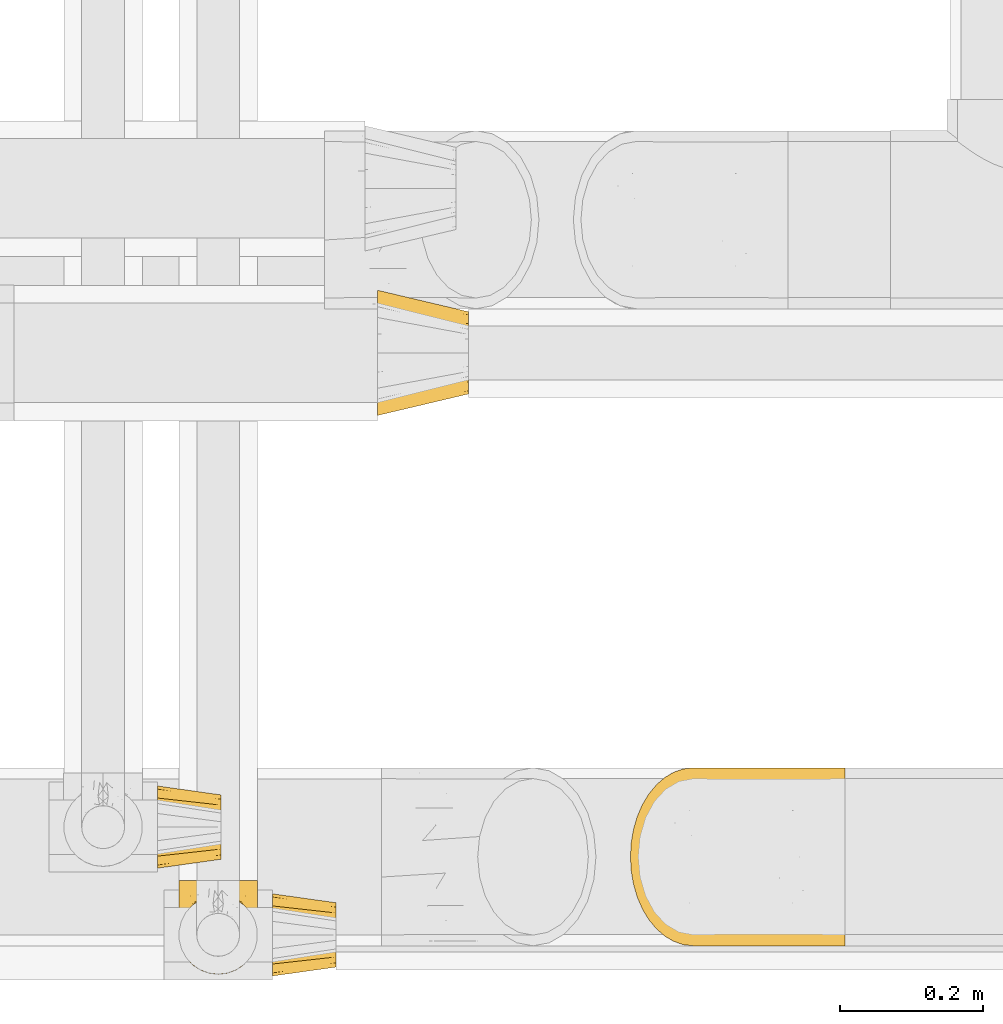
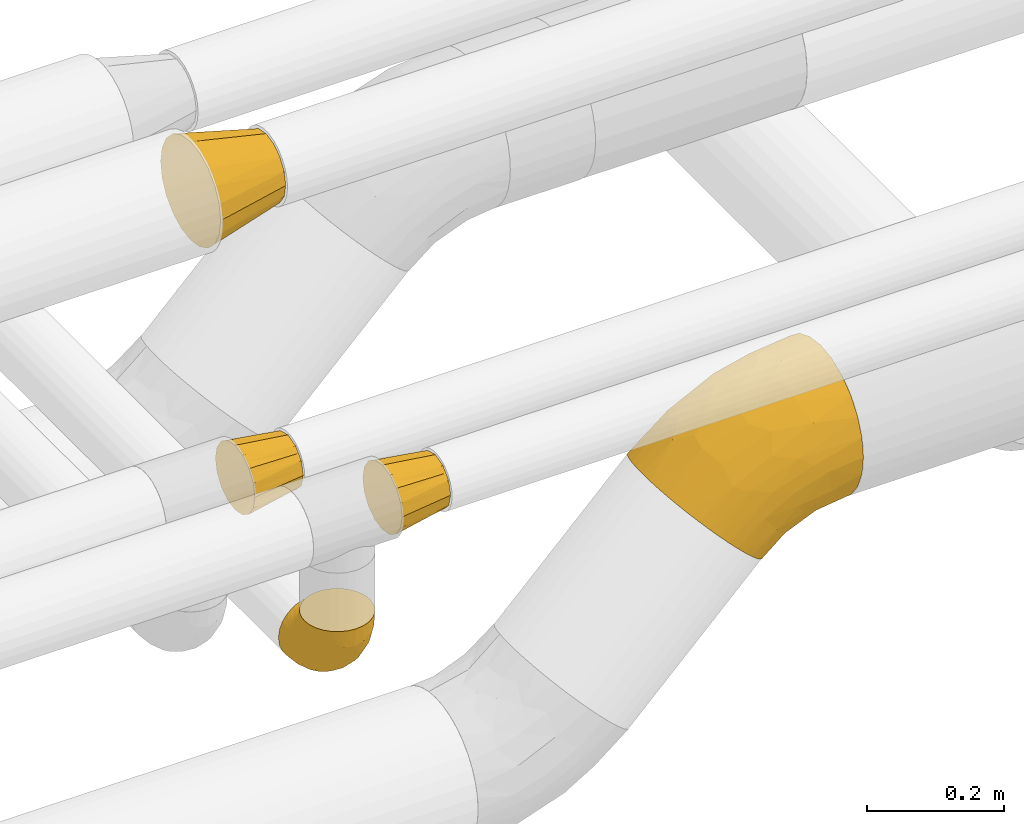
# One storey, part 184 of 827: 5 coverings.
"""IFC2X3 building model written with IfcOpenShell, lengths in millimetres."""

from ifc_helpers import new_model, entity, si_unit, converted_unit, derived_unit, direction, frame, origin, place, context, subcontext, project, spatial, faceted_brep, element, save


model = new_model("IFC2X3")

# Units and contexts
model_context = context("Model", 3, precision=0.01, world=origin(), true_north=direction((6.12303176911189e-17, 1.0)))
body_context = subcontext(model_context, "Body", "Model", "MODEL_VIEW")
ifc_project = project(units=[si_unit("LENGTHUNIT", "METRE", prefix="MILLI"), si_unit("AREAUNIT", "SQUARE_METRE"), si_unit("VOLUMEUNIT", "CUBIC_METRE"), converted_unit("PLANEANGLEUNIT", "DEGREE", entity("IfcRatioMeasure", 0.0174532925199433), si_unit("PLANEANGLEUNIT", "RADIAN"), dimensions=[0, 0, 0, 0, 0, 0, 0]), si_unit("MASSUNIT", "GRAM", prefix="KILO"), derived_unit("MASSDENSITYUNIT", [(si_unit("MASSUNIT", "GRAM", prefix="KILO"), 1), (si_unit("LENGTHUNIT", "METRE"), -3)]), derived_unit("MOMENTOFINERTIAUNIT", [(si_unit("LENGTHUNIT", "METRE"), 4)]), si_unit("TIMEUNIT", "SECOND"), si_unit("FREQUENCYUNIT", "HERTZ"), si_unit("THERMODYNAMICTEMPERATUREUNIT", "DEGREE_CELSIUS"), derived_unit("THERMALTRANSMITTANCEUNIT", [(si_unit("MASSUNIT", "GRAM", prefix="KILO"), 1), (si_unit("THERMODYNAMICTEMPERATUREUNIT", "KELVIN"), -1), (si_unit("TIMEUNIT", "SECOND"), -3)]), derived_unit("VOLUMETRICFLOWRATEUNIT", [(si_unit("LENGTHUNIT", "METRE"), 3), (si_unit("TIMEUNIT", "SECOND"), -1)]), derived_unit("MASSFLOWRATEUNIT", [(si_unit("MASSUNIT", "GRAM", prefix="KILO"), 1), (si_unit("TIMEUNIT", "SECOND"), -1)]), derived_unit("ROTATIONALFREQUENCYUNIT", [(si_unit("TIMEUNIT", "SECOND"), -1)]), si_unit("ELECTRICCURRENTUNIT", "AMPERE"), si_unit("ELECTRICVOLTAGEUNIT", "VOLT"), si_unit("POWERUNIT", "WATT"), si_unit("FORCEUNIT", "NEWTON", prefix="KILO"), si_unit("ILLUMINANCEUNIT", "LUX"), si_unit("LUMINOUSFLUXUNIT", "LUMEN"), si_unit("LUMINOUSINTENSITYUNIT", "CANDELA"), derived_unit("USERDEFINED", [(si_unit("MASSUNIT", "GRAM", prefix="KILO"), -1), (si_unit("LENGTHUNIT", "METRE"), -2), (si_unit("TIMEUNIT", "SECOND"), 3), (si_unit("LUMINOUSFLUXUNIT", "LUMEN"), 1)]), derived_unit("LINEARVELOCITYUNIT", [(si_unit("LENGTHUNIT", "METRE"), 1), (si_unit("TIMEUNIT", "SECOND"), -1)]), si_unit("PRESSUREUNIT", "PASCAL"), derived_unit("USERDEFINED", [(si_unit("LENGTHUNIT", "METRE"), -2), (si_unit("MASSUNIT", "GRAM", prefix="KILO"), 1), (si_unit("TIMEUNIT", "SECOND"), -2)]), derived_unit("LINEARFORCEUNIT", [(si_unit("MASSUNIT", "GRAM", prefix="KILO"), 1), (si_unit("LENGTHUNIT", "METRE"), 1), (si_unit("TIMEUNIT", "SECOND"), -2), (si_unit("LENGTHUNIT", "METRE"), -1)]), derived_unit("PLANARFORCEUNIT", [(si_unit("MASSUNIT", "GRAM", prefix="KILO"), 1), (si_unit("LENGTHUNIT", "METRE"), 1), (si_unit("TIMEUNIT", "SECOND"), -2), (si_unit("LENGTHUNIT", "METRE"), -2)])], contexts=[model_context])

# Site, building, storey
site_placement = place(None, origin())
site = spatial("IfcSite", under=ifc_project, at=site_placement, CompositionType="ELEMENT")
building_placement = place(site_placement, origin())
building = spatial("IfcBuilding", under=site, at=building_placement, CompositionType="ELEMENT")
storey_placement = place(building_placement, frame((0.0, 0.0, 28200.0)))
storey = spatial("IfcBuildingStorey", under=building, at=storey_placement, Name="08", CompositionType="ELEMENT", Elevation=28200.0)

# Coverings
covering_1_placement = place(storey_placement, frame((36852.83, 6990.9, 3010.9)))
element("IfcCovering", 1, at=covering_1_placement, inside=storey, Name=":ADSK_", ObjectType=":ADSK_", PredefinedType="INSULATION", context=body_context, shape_type="Brep", body=[
    faceted_brep([(0.0, 62.06, 172.31), (0.0, 89.1, 176.6), (0.0, 116.13, 172.31), (0.0, 140.53, 159.88), (0.0, 159.88, 140.53), (0.0, 172.31, 116.13), (0.0, 176.6, 89.1), (0.0, 172.31, 62.06), (0.0, 159.88, 37.66), (0.0, 140.53, 18.31), (0.0, 116.13, 5.88), (0.0, 89.1, 1.6), (0.0, 62.06, 5.88), (0.0, 37.66, 18.31), (0.0, 18.31, 37.66), (0.0, 5.88, 62.06), (0.0, 1.6, 89.1), (0.0, 5.88, 116.13), (0.0, 18.31, 140.53), (0.0, 37.66, 159.88), (127.0, 31.6, 89.1), (127.0, 33.78, 78.09), (127.0, 35.97, 67.09), (127.0, 42.2, 57.76), (127.0, 48.44, 48.44), (127.0, 57.76, 42.2), (127.0, 67.09, 35.97), (127.0, 78.09, 33.78), (127.0, 89.1, 31.6), (127.0, 100.1, 33.78), (127.0, 111.1, 35.97), (127.0, 120.43, 42.2), (127.0, 129.75, 48.44), (127.0, 135.99, 57.76), (127.0, 142.22, 67.09), (127.0, 144.41, 78.09), (127.0, 146.6, 89.1), (127.0, 144.41, 100.1), (127.0, 142.22, 111.1), (127.0, 135.99, 120.43), (127.0, 129.75, 129.75), (127.0, 120.43, 135.99), (127.0, 111.1, 142.22), (127.0, 100.1, 144.41), (127.0, 89.1, 146.6), (127.0, 78.09, 144.41), (127.0, 67.09, 142.22), (127.0, 57.76, 135.99), (127.0, 48.44, 129.75), (127.0, 42.2, 120.43), (127.0, 35.97, 111.1), (127.0, 33.78, 100.1)], [[[0, 1, 2, 3, 4, 5, 6, 7, 8, 9, 10, 11, 12, 13, 14, 15, 16, 17, 18, 19]], [[20, 21, 22, 23, 24, 25, 26, 27, 28, 29, 30, 31, 32, 33, 34, 35, 36, 37, 38, 39, 40, 41, 42, 43, 44, 45, 46, 47, 48, 49, 50, 51]], [[6, 35, 7]], [[35, 6, 36]], [[34, 8, 7]], [[10, 30, 29]], [[35, 34, 7]], [[8, 34, 33, 32]], [[9, 32, 31, 30]], [[11, 29, 28]], [[10, 9, 30]], [[11, 10, 29]], [[32, 9, 8]], [[11, 27, 12]], [[27, 11, 28]], [[26, 13, 12]], [[15, 22, 21]], [[27, 26, 12]], [[13, 26, 25, 24]], [[14, 24, 23, 22]], [[16, 21, 20]], [[15, 14, 22]], [[16, 15, 21]], [[24, 14, 13]], [[16, 51, 17]], [[51, 16, 20]], [[50, 18, 17]], [[0, 46, 45]], [[51, 50, 17]], [[18, 50, 49, 48]], [[19, 48, 47, 46]], [[1, 45, 44]], [[0, 19, 46]], [[1, 0, 45]], [[48, 19, 18]], [[1, 43, 2]], [[43, 1, 44]], [[42, 3, 2]], [[5, 38, 37]], [[43, 42, 2]], [[3, 42, 41, 40]], [[4, 40, 39, 38]], [[6, 37, 36]], [[5, 4, 38]], [[6, 5, 37]], [[40, 4, 3]]]),
])
covering_2_placement = place(storey_placement, frame((36572.9, 6209.07, 2793.25)))
element("IfcCovering", 2, at=covering_2_placement, inside=storey, Name=":ADSK_", ObjectType=":ADSK_", PredefinedType="INSULATION", context=body_context, shape_type="Brep", body=[
    faceted_brep([(13.63, 22.35, 132.75), (22.37, 13.62, 132.75), (32.83, 7.05, 132.75), (44.49, 2.97, 132.75), (56.75, 1.6, 132.75), (69.02, 2.98, 132.75), (80.68, 7.06, 132.75), (91.14, 13.63, 132.75), (99.87, 22.37, 132.75), (106.44, 32.83, 132.75), (110.52, 44.49, 132.75), (111.9, 56.75, 132.75), (110.94, 65.19, 132.75), (110.51, 69.02, 132.75), (108.47, 74.85, 132.75), (106.43, 80.68, 132.75), (99.86, 91.14, 132.75), (91.12, 99.87, 132.75), (80.66, 106.44, 132.75), (69.0, 110.52, 132.75), (56.75, 111.9, 132.75), (44.47, 110.51, 132.75), (32.81, 106.43, 132.75), (22.35, 99.86, 132.75), (13.62, 91.12, 132.75), (7.05, 80.66, 132.75), (5.01, 74.83, 132.75), (2.97, 69.0, 132.75), (2.55, 65.19, 132.75), (1.6, 56.75, 132.75), (2.98, 44.47, 132.75), (7.06, 32.81, 132.75), (95.74, 132.75, 95.74), (100.12, 132.75, 90.03), (104.51, 132.75, 84.32), (110.02, 132.75, 71.02), (110.78, 132.75, 65.22), (111.34, 132.75, 60.98), (111.9, 132.75, 56.75), (110.02, 132.75, 42.47), (104.51, 132.75, 29.17), (95.74, 132.75, 17.75), (84.32, 132.75, 8.98), (71.02, 132.75, 3.47), (56.75, 132.75, 1.6), (42.47, 132.75, 3.47), (29.17, 132.75, 8.98), (17.75, 132.75, 17.75), (8.98, 132.75, 29.17), (3.47, 132.75, 42.47), (1.6, 132.75, 56.75), (2.71, 132.75, 65.22), (3.47, 132.75, 71.02), (8.98, 132.75, 84.32), (13.37, 132.75, 90.03), (17.75, 132.75, 95.74), (29.17, 132.75, 104.51), (42.47, 132.75, 110.02), (56.75, 132.75, 111.9), (71.02, 132.75, 110.02), (84.32, 132.75, 104.51), (7.44, 106.09, 35.64), (2.99, 106.29, 48.47), (56.75, 98.8, 6.06), (46.96, 110.62, 4.36), (37.21, 79.56, 16.79), (27.14, 82.88, 20.82), (37.53, 101.82, 8.85), (24.94, 109.51, 13.94), (3.17, 60.24, 80.96), (1.6, 62.53, 103.66), (1.6, 66.65, 97.5), (1.6, 70.77, 91.33), (1.6, 74.89, 85.17), (1.6, 79.01, 79.01), (5.69, 75.42, 54.67), (12.02, 78.6, 38.99), (39.71, 54.94, 30.54), (56.75, 67.17, 19.17), (56.75, 40.01, 40.01), (15.45, 101.35, 24.66), (11.78, 27.42, 109.14), (56.75, 6.06, 98.8), (40.29, 7.89, 101.8), (9.49, 54.81, 63.23), (2.53, 49.8, 109.61), (2.41, 83.59, 62.85), (1.6, 85.17, 74.89), (1.6, 91.33, 70.77), (1.6, 97.5, 66.65), (1.6, 103.66, 62.53), (20.26, 19.66, 101.4), (15.42, 32.92, 80.83), (47.01, 86.86, 10.81), (31.45, 19.74, 79.3), (42.38, 29.98, 54.37), (44.67, 15.6, 76.81), (29.07, 11.19, 109.78), (29.36, 42.02, 48.41), (1.6, 58.54, 123.73), (1.6, 60.33, 114.72), (22.77, 25.28, 80.6), (24.08, 62.01, 35.27), (7.53, 42.85, 86.96), (6.23, 37.14, 110.67), (56.75, 19.17, 67.17), (17.33, 51.44, 52.02), (1.6, 114.72, 60.33), (1.6, 119.22, 59.44), (1.6, 123.73, 58.54), (6.73, 115.76, 82.8), (2.92, 110.4, 72.79), (3.19, 102.67, 77.6), (3.2, 119.74, 71.3), (19.32, 125.52, 98.0), (12.48, 123.09, 90.73), (14.6, 115.24, 96.3), (7.81, 124.18, 82.91), (7.5, 108.76, 87.53), (9.9, 105.53, 94.55), (45.9, 112.2, 125.07), (31.09, 109.92, 117.99), (35.08, 108.4, 125.94), (9.55, 89.3, 113.64), (3.53, 78.37, 103.99), (4.99, 78.09, 116.68), (17.56, 110.58, 102.88), (22.47, 108.54, 110.61), (31.26, 114.9, 112.36), (44.17, 124.4, 112.06), (25.83, 124.83, 103.46), (13.83, 92.2, 124.54), (20.99, 100.98, 120.6), (2.74, 69.61, 118.13), (4.52, 87.39, 96.16), (18.5, 102.3, 113.04), (2.46, 70.27, 110.58), (43.31, 116.83, 116.83), (56.75, 114.69, 122.32), (56.75, 122.32, 114.69), (8.84, 94.21, 103.01), (29.08, 120.17, 107.4), (7.16, 96.46, 95.69), (4.76, 97.77, 87.01), (3.35, 89.34, 88.18), (13.82, 101.91, 105.15), (84.41, 120.17, 107.4), (87.67, 124.84, 103.46), (110.29, 102.67, 77.6), (111.9, 97.5, 66.65), (110.57, 110.4, 72.79), (69.32, 124.4, 112.06), (111.9, 58.54, 123.73), (111.9, 60.33, 114.72), (110.14, 89.33, 88.19), (111.9, 79.01, 79.01), (111.9, 85.17, 74.89), (70.16, 116.83, 116.83), (67.57, 112.21, 125.08), (92.48, 101.0, 120.61), (82.38, 109.94, 117.98), (78.39, 108.4, 125.94), (111.9, 114.72, 60.33), (111.9, 123.73, 58.54), (111.9, 128.24, 57.64), (95.92, 110.6, 102.88), (91.0, 108.57, 110.61), (99.66, 101.94, 105.15), (94.16, 125.53, 98.0), (101.59, 119.28, 90.96), (108.5, 78.12, 116.68), (111.9, 103.66, 62.53), (110.29, 119.74, 71.3), (106.76, 115.76, 82.8), (105.99, 108.77, 87.53), (105.68, 124.18, 82.91), (108.96, 87.39, 96.19), (111.9, 74.89, 85.17), (111.9, 62.53, 103.66), (110.74, 69.63, 118.15), (99.65, 92.22, 124.54), (94.97, 102.32, 113.04), (103.92, 89.33, 113.63), (109.95, 78.39, 103.99), (103.58, 105.54, 94.56), (111.03, 70.28, 110.59), (111.9, 66.65, 97.5), (98.89, 115.25, 96.3), (104.63, 94.22, 103.04), (106.33, 96.46, 95.7), (108.72, 97.78, 87.02), (82.21, 114.91, 112.37), (111.9, 70.77, 91.33), (111.9, 91.33, 70.77), (111.08, 83.59, 62.85), (106.06, 106.09, 35.64), (105.97, 42.86, 86.97), (110.32, 60.25, 80.97), (110.96, 49.81, 109.62), (66.48, 88.41, 10.24), (110.5, 106.29, 48.47), (75.96, 101.81, 8.85), (66.4, 110.86, 4.3), (88.55, 109.5, 13.95), (98.04, 101.34, 24.66), (86.35, 82.87, 20.83), (84.14, 42.02, 48.41), (71.11, 29.98, 54.37), (73.77, 54.94, 30.54), (107.8, 75.43, 54.67), (96.17, 51.45, 52.03), (101.47, 78.59, 39.0), (104.01, 54.82, 63.25), (101.72, 27.44, 109.14), (98.08, 32.93, 80.83), (82.06, 19.76, 79.27), (93.25, 19.67, 101.39), (90.73, 25.31, 80.58), (89.43, 62.02, 35.28), (73.22, 7.9, 101.78), (84.44, 11.2, 109.77), (70.22, 15.96, 76.83), (75.29, 77.26, 17.47), (107.27, 37.15, 110.68)], [[[0, 1, 2, 3, 4, 5, 6, 7, 8, 9, 10, 11, 12, 13, 14, 15, 16, 17, 18, 19, 20, 21, 22, 23, 24, 25, 26, 27, 28, 29, 30, 31]], [[32, 33, 34, 35, 36, 37, 38, 39, 40, 41, 42, 43, 44, 45, 46, 47, 48, 49, 50, 51, 52, 53, 54, 55, 56, 57, 58, 59, 60]], [[49, 61, 62]], [[44, 63, 64]], [[65, 66, 67]], [[67, 66, 68]], [[69, 70, 71, 72, 73, 74]], [[75, 61, 76]], [[77, 78, 79]], [[61, 48, 80]], [[47, 80, 48]], [[68, 47, 46]], [[81, 0, 31]], [[82, 3, 83]], [[46, 45, 67]], [[50, 49, 62]], [[84, 75, 76]], [[85, 30, 29]], [[86, 74, 87, 88, 89, 90]], [[91, 81, 92]], [[93, 65, 67]], [[94, 95, 96]], [[47, 68, 80]], [[79, 95, 77]], [[2, 83, 3]], [[82, 83, 96]], [[97, 2, 1]], [[3, 82, 4]], [[84, 69, 75]], [[86, 69, 74]], [[98, 77, 95]], [[97, 83, 2]], [[85, 29, 99, 100, 70]], [[101, 91, 92]], [[77, 98, 102]], [[91, 1, 0]], [[103, 104, 85]], [[103, 81, 104]], [[102, 76, 80]], [[64, 93, 67]], [[97, 94, 83]], [[45, 64, 67]], [[48, 61, 49]], [[81, 91, 0]], [[96, 95, 105]], [[79, 105, 95]], [[101, 98, 94]], [[1, 91, 97]], [[94, 97, 91]], [[104, 81, 31]], [[92, 81, 103]], [[84, 92, 103]], [[106, 98, 101]], [[76, 61, 80]], [[75, 86, 62]], [[102, 80, 66]], [[84, 76, 106]], [[75, 62, 61]], [[62, 90, 107, 108, 109, 50]], [[70, 69, 85]], [[103, 85, 69]], [[94, 98, 95]], [[102, 98, 106]], [[31, 30, 104]], [[85, 104, 30]], [[67, 68, 46]], [[80, 68, 66]], [[62, 86, 90]], [[69, 86, 75]], [[76, 102, 106]], [[77, 102, 66]], [[92, 84, 106]], [[69, 84, 103]], [[44, 64, 45]], [[93, 64, 63]], [[63, 78, 93]], [[77, 93, 78]], [[93, 77, 65]], [[77, 66, 65]], [[82, 96, 105]], [[94, 96, 83]], [[101, 92, 106]], [[94, 91, 101]], [[110, 111, 112]], [[107, 90, 113]], [[114, 115, 116]], [[52, 107, 113]], [[115, 54, 117]], [[118, 119, 116]], [[120, 121, 122]], [[123, 124, 125]], [[99, 29, 28, 27, 100]], [[126, 127, 128]], [[129, 58, 57]], [[56, 114, 130]], [[131, 132, 123]], [[26, 25, 133]], [[130, 57, 56]], [[114, 56, 55]], [[134, 72, 124]], [[121, 127, 135]], [[23, 22, 132]], [[24, 131, 125]], [[24, 125, 25]], [[136, 133, 125]], [[120, 137, 121]], [[137, 138, 139]], [[126, 116, 119]], [[133, 70, 100]], [[138, 120, 20]], [[100, 26, 133]], [[123, 135, 140]], [[129, 141, 128]], [[51, 50, 109, 108, 107, 52]], [[22, 122, 132]], [[21, 122, 22]], [[113, 117, 53]], [[23, 131, 24]], [[142, 119, 143]], [[111, 89, 112]], [[112, 87, 143]], [[144, 134, 142]], [[118, 110, 112]], [[129, 137, 139]], [[128, 141, 126]], [[111, 113, 90]], [[52, 113, 53]], [[74, 73, 144]], [[145, 142, 140]], [[122, 21, 120]], [[132, 122, 121]], [[20, 120, 21]], [[137, 120, 138]], [[58, 129, 139]], [[141, 129, 57]], [[100, 27, 26]], [[25, 125, 133]], [[134, 124, 123]], [[124, 71, 136]], [[89, 88, 87, 112]], [[111, 110, 117]], [[143, 87, 144]], [[118, 116, 115]], [[112, 143, 118]], [[119, 118, 143]], [[143, 144, 142]], [[126, 119, 145]], [[127, 126, 145]], [[130, 126, 141]], [[140, 142, 134]], [[145, 119, 142]], [[135, 127, 145]], [[127, 121, 128]], [[121, 137, 128]], [[129, 128, 137]], [[73, 72, 134]], [[111, 90, 89]], [[74, 144, 87]], [[134, 123, 140]], [[135, 123, 132]], [[140, 135, 145]], [[121, 135, 132]], [[132, 131, 23]], [[125, 131, 123]], [[115, 114, 55]], [[116, 126, 130]], [[117, 113, 111]], [[115, 110, 118]], [[117, 54, 53]], [[115, 55, 54]], [[115, 117, 110]], [[116, 130, 114]], [[57, 130, 141]], [[144, 73, 134]], [[124, 136, 125]], [[70, 133, 136]], [[71, 124, 72]], [[71, 70, 136]], [[59, 146, 147]], [[148, 149, 150]], [[58, 139, 151]], [[12, 11, 152, 153, 13]], [[154, 155, 156]], [[138, 157, 139]], [[138, 158, 157]], [[159, 160, 161]], [[37, 36, 35, 162, 163, 164, 38]], [[165, 166, 167]], [[168, 169, 32]], [[60, 168, 32]], [[170, 16, 15]], [[171, 162, 172]], [[173, 174, 148]], [[169, 173, 175]], [[161, 158, 19]], [[154, 176, 177]], [[20, 19, 158]], [[178, 179, 153]], [[172, 35, 34]], [[17, 16, 180]], [[18, 17, 159]], [[167, 166, 181]], [[170, 182, 180]], [[182, 170, 183]], [[167, 184, 165]], [[185, 186, 183]], [[185, 179, 178]], [[14, 153, 179]], [[157, 151, 139]], [[187, 168, 147]], [[182, 188, 181]], [[19, 18, 161]], [[189, 154, 190]], [[180, 159, 17]], [[172, 150, 171]], [[190, 184, 189]], [[188, 167, 181]], [[190, 174, 184]], [[166, 191, 160]], [[151, 146, 59]], [[35, 172, 162]], [[172, 34, 175]], [[188, 176, 189]], [[176, 182, 183]], [[159, 161, 18]], [[158, 160, 157]], [[158, 161, 160]], [[20, 158, 138]], [[151, 157, 191]], [[58, 151, 59]], [[170, 15, 179]], [[14, 13, 153]], [[183, 170, 185]], [[192, 183, 186]], [[175, 150, 172]], [[150, 173, 148]], [[173, 169, 174]], [[154, 156, 190]], [[184, 174, 187]], [[190, 148, 174]], [[165, 184, 187]], [[189, 176, 154]], [[147, 165, 187]], [[191, 166, 165]], [[184, 167, 189]], [[188, 189, 167]], [[191, 165, 146]], [[181, 160, 159]], [[151, 191, 146]], [[157, 160, 191]], [[176, 192, 177]], [[148, 190, 156]], [[149, 148, 156, 193]], [[149, 171, 150]], [[182, 176, 188]], [[160, 181, 166]], [[181, 159, 182]], [[170, 180, 16]], [[159, 180, 182]], [[147, 168, 60]], [[169, 168, 187]], [[174, 169, 187]], [[175, 34, 33]], [[169, 175, 33]], [[32, 169, 33]], [[175, 173, 150]], [[59, 147, 60]], [[147, 146, 165]], [[192, 176, 183]], [[155, 154, 177]], [[170, 179, 185]], [[185, 178, 186]], [[179, 15, 14]], [[194, 171, 149, 193, 156, 155]], [[195, 40, 39]], [[196, 197, 198]], [[78, 63, 199]], [[197, 155, 177, 192, 186, 178]], [[200, 38, 164, 163, 162, 171]], [[201, 199, 202]], [[203, 204, 205]], [[44, 43, 202]], [[206, 207, 208]], [[194, 197, 209]], [[203, 201, 42]], [[42, 201, 43]], [[41, 203, 42]], [[210, 211, 212]], [[204, 41, 40]], [[212, 197, 196]], [[78, 208, 79]], [[198, 178, 153, 152, 11]], [[204, 195, 211]], [[11, 10, 198]], [[196, 213, 214]], [[206, 215, 207]], [[213, 8, 216]], [[204, 40, 195]], [[8, 213, 9]], [[210, 217, 206]], [[216, 8, 7]], [[210, 206, 218]], [[219, 220, 6]], [[220, 7, 6]], [[207, 105, 79]], [[221, 207, 215]], [[222, 199, 201]], [[5, 4, 82]], [[5, 82, 219]], [[209, 195, 200]], [[215, 216, 220]], [[6, 5, 219]], [[207, 79, 208]], [[221, 82, 105]], [[9, 213, 223]], [[222, 201, 205]], [[204, 211, 218]], [[221, 215, 219]], [[215, 220, 219]], [[216, 7, 220]], [[214, 213, 216]], [[223, 213, 196]], [[217, 214, 216]], [[212, 214, 210]], [[200, 195, 39]], [[211, 195, 209]], [[212, 211, 209]], [[211, 210, 218]], [[38, 200, 39]], [[200, 171, 194]], [[198, 10, 223]], [[197, 178, 198]], [[218, 208, 205]], [[210, 214, 217]], [[198, 223, 196]], [[10, 9, 223]], [[204, 203, 41]], [[201, 203, 205]], [[197, 194, 155]], [[200, 194, 209]], [[208, 218, 206]], [[218, 205, 204]], [[197, 212, 209]], [[214, 212, 196]], [[205, 208, 222]], [[78, 222, 208]], [[78, 199, 222]], [[202, 199, 63]], [[44, 202, 63]], [[201, 202, 43]], [[82, 221, 219]], [[105, 207, 221]], [[216, 215, 217]], [[206, 217, 215]]]),
])
covering_3_placement = place(storey_placement, frame((37204.73, 6248.9, 2722.5)))
element("IfcCovering", 3, at=covering_3_placement, inside=storey, Name=":ADSK_", ObjectType=":ADSK_", PredefinedType="INSULATION", context=body_context, shape_type="Brep", body=[
    faceted_brep([(168.07, 69.57, 11.19), (160.85, 52.91, 18.41), (151.88, 38.06, 27.38), (141.37, 25.37, 37.89), (129.59, 15.16, 49.67), (116.83, 7.69, 62.43), (103.4, 3.13, 75.86), (89.63, 1.6, 89.63), (75.86, 3.13, 103.4), (62.42, 7.69, 116.84), (49.66, 15.17, 129.6), (37.88, 25.37, 141.38), (27.38, 38.06, 151.88), (18.41, 52.92, 160.85), (11.19, 69.58, 168.07), (5.9, 87.63, 173.36), (2.68, 106.63, 176.58), (1.6, 126.1, 177.66), (2.68, 145.57, 176.58), (5.9, 164.57, 173.36), (11.19, 182.62, 168.07), (18.41, 199.28, 160.85), (27.38, 214.13, 151.88), (37.89, 226.82, 141.37), (49.67, 237.03, 129.59), (62.43, 244.5, 116.83), (75.86, 249.06, 103.4), (89.63, 250.6, 89.63), (103.4, 249.06, 75.86), (116.84, 244.5, 62.42), (129.6, 237.02, 49.66), (141.38, 226.82, 37.88), (151.88, 214.13, 27.38), (160.85, 199.27, 18.41), (168.07, 182.61, 11.19), (173.36, 164.56, 5.9), (176.58, 145.56, 2.68), (177.66, 126.1, 1.6), (176.58, 106.62, 2.68), (173.36, 87.62, 5.9), (301.76, 158.32, 57.24), (301.76, 188.35, 69.68), (301.76, 214.13, 89.46), (301.76, 233.92, 115.25), (301.76, 246.35, 145.28), (301.76, 250.6, 177.5), (301.76, 246.35, 209.72), (301.76, 233.92, 239.75), (301.76, 214.13, 265.53), (301.76, 188.35, 285.32), (301.76, 158.32, 297.76), (301.76, 126.1, 302.0), (301.76, 93.87, 297.76), (301.76, 63.85, 285.32), (301.76, 38.06, 265.53), (301.76, 18.28, 239.75), (301.76, 5.84, 209.72), (301.76, 1.6, 177.5), (301.76, 5.84, 145.28), (301.76, 18.28, 115.25), (301.76, 38.06, 89.46), (301.76, 63.85, 69.68), (301.76, 93.87, 57.24), (301.76, 126.1, 53.0), (209.18, 103.13, 289.59), (140.86, 94.62, 265.95), (220.96, 79.57, 285.05), (235.36, 126.1, 296.77), (74.84, 79.65, 225.58), (90.04, 46.81, 212.14), (94.76, 23.33, 184.51), (171.35, 40.8, 245.78), (109.04, 126.1, 255.73), (170.58, 126.1, 281.22), (52.25, 126.1, 220.93), (76.18, 103.27, 234.6), (221.61, 56.05, 272.37), (144.57, 63.66, 253.69), (196.26, 10.26, 206.64), (117.27, 12.22, 175.32), (150.69, 4.26, 165.96), (231.84, 27.61, 247.1), (159.29, 22.41, 217.79), (219.9, 3.79, 190.23), (186.96, 1.6, 154.66), (243.24, 1.6, 171.73), (135.09, 1.6, 126.94), (251.13, 8.94, 130.36), (195.1, 5.03, 126.57), (207.9, 15.16, 102.17), (239.9, 33.02, 85.82), (249.31, 19.37, 107.48), (204.77, 76.39, 36.03), (233.81, 103.53, 41.54), (252.84, 81.68, 54.56), (160.41, 8.86, 93.45), (262.83, 62.28, 66.63), (225.77, 56.89, 58.72), (191.47, 56.9, 40.13), (256.34, 126.1, 47.02), (185.15, 28.41, 67.36), (214.01, 126.1, 29.49), (220.55, 152.84, 36.35), (259.28, 158.12, 52.09), (239.72, 243.7, 129.11), (186.96, 250.6, 154.66), (243.24, 250.6, 171.73), (261.61, 227.17, 101.23), (215.5, 225.77, 85.74), (247.45, 204.15, 73.1), (193.4, 209.83, 54.89), (231.97, 177.23, 50.43), (197.87, 175.4, 31.39), (269.16, 178.7, 61.8), (176.24, 244.1, 105.55), (175.91, 226.57, 65.79), (135.09, 250.6, 126.94), (196.26, 241.93, 206.63), (231.83, 224.59, 247.09), (171.35, 211.4, 245.77), (221.64, 196.15, 272.37), (219.89, 248.4, 190.22), (150.7, 247.93, 165.96), (209.18, 149.06, 289.59), (90.04, 205.38, 212.13), (144.57, 188.53, 253.69), (220.97, 172.62, 285.05), (140.86, 157.58, 265.95), (159.29, 229.79, 217.78), (76.17, 148.93, 234.6), (74.85, 172.55, 225.58), (94.76, 228.87, 184.5), (117.27, 239.97, 175.31)], [[[0, 1, 2, 3, 4, 5, 6, 7, 8, 9, 10, 11, 12, 13, 14, 15, 16, 17, 18, 19, 20, 21, 22, 23, 24, 25, 26, 27, 28, 29, 30, 31, 32, 33, 34, 35, 36, 37, 38, 39]], [[40, 41, 42, 43, 44, 45, 46, 47, 48, 49, 50, 51, 52, 53, 54, 55, 56, 57, 58, 59, 60, 61, 62, 63]], [[64, 65, 66]], [[67, 52, 51]], [[68, 14, 13]], [[69, 70, 71]], [[72, 65, 73]], [[72, 74, 75]], [[13, 12, 69]], [[64, 73, 65]], [[70, 12, 11]], [[76, 66, 77]], [[78, 79, 80]], [[55, 81, 78]], [[78, 82, 79]], [[80, 9, 8]], [[76, 77, 71]], [[57, 56, 83]], [[78, 80, 83]], [[68, 69, 77]], [[77, 69, 71]], [[84, 85, 83]], [[14, 68, 15]], [[77, 65, 68]], [[69, 68, 13]], [[75, 68, 65]], [[78, 81, 82]], [[70, 69, 12]], [[68, 75, 15]], [[16, 74, 17]], [[53, 66, 76]], [[76, 71, 81]], [[54, 76, 81]], [[54, 81, 55]], [[86, 8, 7]], [[84, 80, 86]], [[80, 84, 83]], [[53, 52, 66]], [[64, 52, 67]], [[82, 70, 79]], [[81, 71, 82]], [[86, 80, 8]], [[76, 54, 53]], [[79, 10, 9]], [[10, 79, 70]], [[55, 78, 56]], [[77, 66, 65]], [[75, 16, 15]], [[72, 75, 65]], [[80, 79, 9]], [[16, 75, 74]], [[70, 82, 71]], [[10, 70, 11]], [[57, 83, 85]], [[56, 78, 83]], [[52, 64, 66]], [[73, 64, 67]], [[58, 85, 87]], [[58, 57, 85]], [[87, 85, 88]], [[89, 90, 91]], [[91, 60, 59]], [[91, 87, 89]], [[92, 93, 94]], [[38, 93, 92]], [[88, 95, 89]], [[96, 97, 94]], [[94, 97, 92]], [[98, 2, 1]], [[88, 85, 84]], [[99, 63, 62]], [[93, 62, 94]], [[61, 94, 62]], [[98, 0, 92]], [[38, 92, 39]], [[100, 4, 3]], [[87, 88, 89]], [[3, 2, 100]], [[100, 95, 4]], [[6, 95, 86]], [[98, 100, 2]], [[90, 97, 96]], [[5, 95, 6]], [[7, 6, 86]], [[93, 101, 99]], [[0, 98, 1]], [[62, 93, 99]], [[59, 58, 87]], [[37, 101, 38]], [[93, 38, 101]], [[86, 95, 88]], [[100, 90, 89]], [[0, 39, 92]], [[95, 100, 89]], [[90, 96, 60]], [[92, 97, 98]], [[90, 100, 97]], [[100, 98, 97]], [[5, 4, 95]], [[94, 61, 96]], [[86, 88, 84]], [[96, 61, 60]], [[60, 91, 90]], [[59, 87, 91]], [[102, 103, 99]], [[104, 105, 106]], [[102, 99, 101]], [[104, 107, 108]], [[109, 107, 42]], [[103, 63, 99]], [[110, 111, 112]], [[109, 111, 110]], [[36, 102, 101]], [[113, 103, 111]], [[114, 104, 108]], [[45, 44, 106]], [[104, 44, 43]], [[41, 109, 42]], [[109, 108, 107]], [[106, 44, 104]], [[104, 43, 107]], [[104, 114, 105]], [[36, 35, 102]], [[30, 115, 31]], [[115, 30, 114]], [[43, 42, 107]], [[34, 112, 35]], [[35, 112, 102]], [[33, 110, 112]], [[113, 40, 103]], [[115, 110, 32]], [[31, 115, 32]], [[116, 114, 29]], [[33, 32, 110]], [[110, 115, 108]], [[114, 30, 29]], [[109, 110, 108]], [[114, 116, 105]], [[112, 111, 102]], [[102, 111, 103]], [[28, 27, 116]], [[29, 28, 116]], [[113, 109, 41]], [[112, 34, 33]], [[109, 113, 111]], [[36, 101, 37]], [[40, 113, 41]], [[103, 40, 63]], [[114, 108, 115]], [[117, 47, 46]], [[117, 118, 47]], [[118, 119, 120]], [[121, 122, 117]], [[73, 67, 123]], [[119, 124, 125]], [[122, 121, 105]], [[106, 121, 45]], [[123, 126, 127]], [[118, 128, 119]], [[67, 51, 50]], [[129, 130, 19]], [[48, 120, 49]], [[125, 127, 126]], [[50, 126, 123]], [[73, 127, 72]], [[19, 18, 129]], [[131, 119, 128]], [[126, 50, 49]], [[130, 20, 19]], [[24, 132, 25]], [[126, 49, 120]], [[116, 27, 26]], [[131, 22, 124]], [[118, 48, 47]], [[132, 122, 25]], [[132, 131, 128]], [[121, 106, 105]], [[117, 128, 118]], [[131, 24, 23]], [[125, 126, 120]], [[124, 22, 21]], [[124, 21, 130]], [[130, 21, 20]], [[26, 122, 116]], [[129, 18, 74]], [[127, 130, 129]], [[132, 117, 122]], [[17, 74, 18]], [[127, 125, 130]], [[124, 130, 125]], [[127, 129, 72]], [[122, 105, 116]], [[48, 118, 120]], [[132, 128, 117]], [[25, 122, 26]], [[120, 119, 125]], [[119, 131, 124]], [[72, 129, 74]], [[24, 131, 132]], [[131, 23, 22]], [[117, 46, 121]], [[45, 121, 46]], [[73, 123, 127]], [[50, 123, 67]]]),
])
covering_4_placement = place(storey_placement, frame((36705.64, 6206.61, 3040.9)))
element("IfcCovering", 4, at=covering_4_placement, inside=storey, Name=":ADSK_", ObjectType=":ADSK_", PredefinedType="INSULATION", context=body_context, shape_type="Brep", body=[
    faceted_brep([(89.0, 47.78, 101.06), (89.0, 36.54, 98.03), (89.0, 28.31, 89.79), (89.0, 20.09, 81.54), (89.0, 17.09, 70.28), (89.0, 14.1, 59.03), (89.0, 17.13, 47.78), (89.0, 20.16, 36.54), (89.0, 28.4, 28.31), (89.0, 36.65, 20.09), (89.0, 47.91, 17.09), (89.0, 59.16, 14.1), (89.0, 70.41, 17.13), (89.0, 81.65, 20.16), (89.0, 89.88, 28.4), (89.0, 98.1, 36.65), (89.0, 101.1, 47.91), (89.0, 104.1, 59.16), (89.0, 101.06, 70.41), (89.0, 98.03, 81.65), (89.0, 89.79, 89.88), (89.0, 81.54, 98.1), (89.0, 70.28, 101.1), (89.0, 59.03, 104.1), (0.0, 116.6, 59.18), (0.0, 114.42, 48.17), (0.0, 112.25, 37.17), (0.0, 106.03, 27.83), (0.0, 99.81, 18.5), (0.0, 90.5, 12.25), (0.0, 81.18, 6.0), (0.0, 70.18, 3.8), (0.0, 59.18, 1.6), (0.0, 48.17, 3.77), (0.0, 37.17, 5.94), (0.0, 27.83, 12.16), (0.0, 18.5, 18.38), (0.0, 12.25, 27.69), (0.0, 6.0, 37.01), (0.0, 3.8, 48.01), (0.0, 1.6, 59.01), (0.0, 3.77, 70.02), (0.0, 5.94, 81.02), (0.0, 12.16, 90.36), (0.0, 18.38, 99.69), (0.0, 27.69, 105.94), (0.0, 37.01, 112.19), (0.0, 48.01, 114.39), (0.0, 59.01, 116.6), (0.0, 70.02, 114.42), (0.0, 81.02, 112.25), (0.0, 90.36, 106.03), (0.0, 99.69, 99.81), (0.0, 105.94, 90.5), (0.0, 112.19, 81.18), (0.0, 114.39, 70.18)], [[[0, 1, 2, 3, 4, 5, 6, 7, 8, 9, 10, 11, 12, 13, 14, 15, 16, 17, 18, 19, 20, 21, 22, 23]], [[24, 25, 26, 27, 28, 29, 30, 31, 32, 33, 34, 35, 36, 37, 38, 39, 40, 41, 42, 43, 44, 45, 46, 47, 48, 49, 50, 51, 52, 53, 54, 55]], [[49, 48, 23]], [[19, 54, 53]], [[51, 50, 21]], [[51, 21, 20]], [[19, 53, 20]], [[51, 20, 52]], [[55, 54, 18]], [[23, 22, 49]], [[53, 52, 20]], [[17, 55, 18]], [[22, 21, 50]], [[55, 17, 24]], [[54, 19, 18]], [[22, 50, 49]], [[41, 40, 5]], [[1, 46, 45]], [[43, 42, 3]], [[43, 3, 2]], [[1, 45, 2]], [[43, 2, 44]], [[47, 46, 0]], [[5, 4, 41]], [[45, 44, 2]], [[23, 47, 0]], [[4, 3, 42]], [[47, 23, 48]], [[46, 1, 0]], [[4, 42, 41]], [[33, 32, 11]], [[7, 38, 37]], [[35, 34, 9]], [[35, 9, 8]], [[7, 37, 8]], [[35, 8, 36]], [[39, 38, 6]], [[11, 10, 33]], [[37, 36, 8]], [[5, 39, 6]], [[10, 9, 34]], [[39, 5, 40]], [[38, 7, 6]], [[10, 34, 33]], [[25, 24, 17]], [[13, 30, 29]], [[27, 26, 15]], [[27, 15, 14]], [[13, 29, 14]], [[27, 14, 28]], [[31, 30, 12]], [[17, 16, 25]], [[29, 28, 14]], [[11, 31, 12]], [[16, 15, 26]], [[31, 11, 32]], [[30, 13, 12]], [[16, 26, 25]]]),
])
covering_5_placement = place(storey_placement, frame((36544.72, 6357.47, 3040.9)))
element("IfcCovering", 5, at=covering_5_placement, inside=storey, Name=":ADSK_", ObjectType=":ADSK_", PredefinedType="INSULATION", context=body_context, shape_type="Brep", body=[
    faceted_brep([(89.0, 36.6, 98.07), (89.0, 28.36, 89.83), (89.0, 20.12, 81.6), (89.0, 17.11, 70.35), (89.0, 14.1, 59.1), (89.0, 17.11, 47.85), (89.0, 20.12, 36.6), (89.0, 28.36, 28.36), (89.0, 36.6, 20.12), (89.0, 47.85, 17.11), (89.0, 59.1, 14.1), (89.0, 70.35, 17.11), (89.0, 81.6, 20.12), (89.0, 89.83, 28.36), (89.0, 98.07, 36.6), (89.0, 101.08, 47.85), (89.0, 104.1, 59.1), (89.0, 101.08, 70.35), (89.0, 98.07, 81.6), (89.0, 89.83, 89.83), (89.0, 81.6, 98.07), (89.0, 70.35, 101.08), (89.0, 59.1, 104.1), (89.0, 47.85, 101.08), (0.0, 116.6, 59.1), (0.0, 114.41, 48.09), (0.0, 112.22, 37.09), (0.0, 105.99, 27.76), (0.0, 99.75, 18.44), (0.0, 90.43, 12.2), (0.0, 81.1, 5.97), (0.0, 70.1, 3.78), (0.0, 59.1, 1.6), (0.0, 48.09, 3.78), (0.0, 37.09, 5.97), (0.0, 27.76, 12.2), (0.0, 18.44, 18.44), (0.0, 12.2, 27.76), (0.0, 5.97, 37.09), (0.0, 3.78, 48.09), (0.0, 1.6, 59.1), (0.0, 3.78, 70.1), (0.0, 5.97, 81.1), (0.0, 12.2, 90.43), (0.0, 18.44, 99.75), (0.0, 27.76, 105.99), (0.0, 37.09, 112.22), (0.0, 48.09, 114.41), (0.0, 59.1, 116.6), (0.0, 70.1, 114.41), (0.0, 81.1, 112.22), (0.0, 90.43, 105.99), (0.0, 99.75, 99.75), (0.0, 105.99, 90.43), (0.0, 112.22, 81.1), (0.0, 114.41, 70.1)], [[[0, 1, 2, 3, 4, 5, 6, 7, 8, 9, 10, 11, 12, 13, 14, 15, 16, 17, 18, 19, 20, 21, 22, 23]], [[24, 25, 26, 27, 28, 29, 30, 31, 32, 33, 34, 35, 36, 37, 38, 39, 40, 41, 42, 43, 44, 45, 46, 47, 48, 49, 50, 51, 52, 53, 54, 55]], [[49, 48, 22]], [[18, 54, 53]], [[51, 50, 20]], [[51, 20, 19]], [[18, 53, 19]], [[51, 19, 52]], [[55, 54, 17]], [[22, 21, 49]], [[53, 52, 19]], [[16, 55, 17]], [[21, 20, 50]], [[55, 16, 24]], [[54, 18, 17]], [[21, 50, 49]], [[41, 40, 4]], [[0, 46, 45]], [[43, 42, 2]], [[43, 2, 1]], [[0, 45, 1]], [[43, 1, 44]], [[47, 46, 23]], [[4, 3, 41]], [[45, 44, 1]], [[22, 47, 23]], [[3, 2, 42]], [[47, 22, 48]], [[46, 0, 23]], [[3, 42, 41]], [[33, 32, 10]], [[6, 38, 37]], [[35, 34, 8]], [[35, 8, 7]], [[6, 37, 7]], [[35, 7, 36]], [[39, 38, 5]], [[10, 9, 33]], [[37, 36, 7]], [[4, 39, 5]], [[9, 8, 34]], [[39, 4, 40]], [[38, 6, 5]], [[9, 34, 33]], [[25, 24, 16]], [[12, 30, 29]], [[27, 26, 14]], [[27, 14, 13]], [[12, 29, 13]], [[27, 13, 28]], [[31, 30, 11]], [[16, 15, 25]], [[29, 28, 13]], [[10, 31, 11]], [[15, 14, 26]], [[31, 10, 32]], [[30, 12, 11]], [[15, 26, 25]]]),
])

save(model, "model.ifc")
